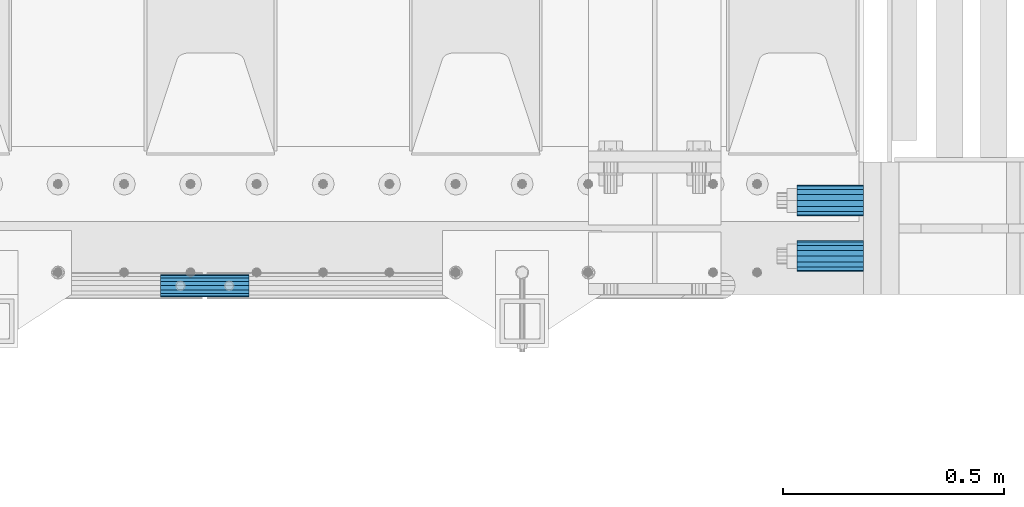
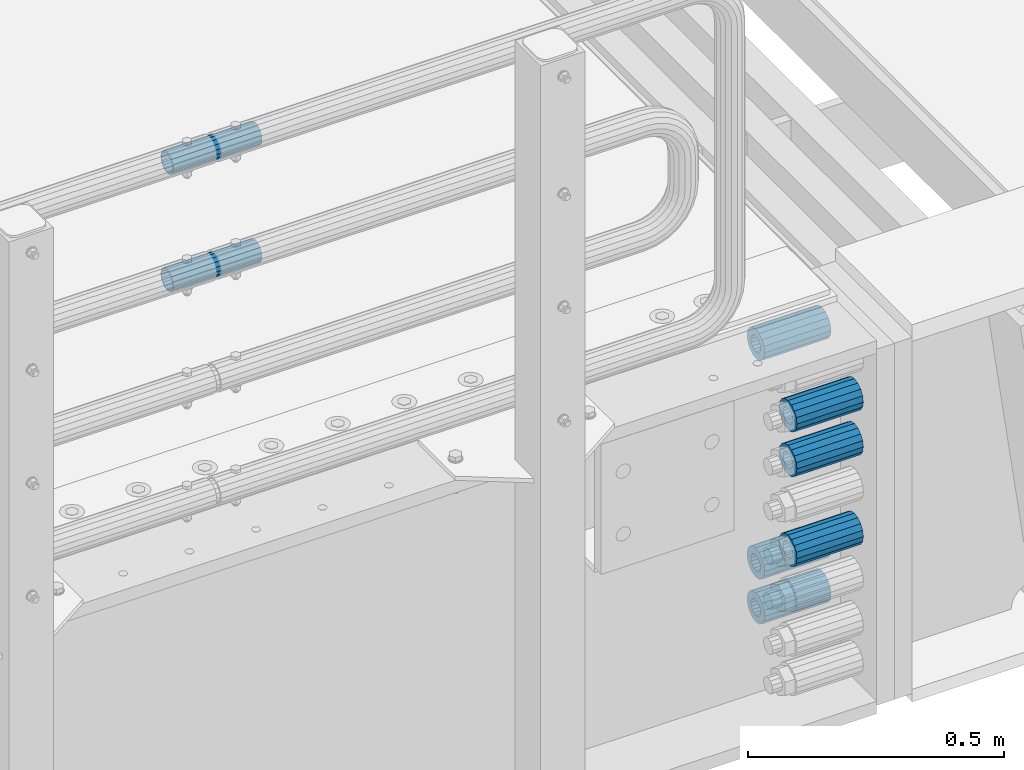
# One storey, part 127 of 219: 8 beams.
"""IFC2X3 building model written with IfcOpenShell, lengths in millimetres."""

from ifc_helpers import new_model, si_unit, frame, origin_with_axes, place, context, subcontext, project, spatial, faceted_brep, material, type_object, element, save


model = new_model("IFC2X3")

# Units and contexts
model_context = context("Model", 3, precision=1e-05, world=origin_with_axes())
body_context = subcontext(model_context, "Body", "Model", "MODEL_VIEW")
ifc_project = project(units=[si_unit("LENGTHUNIT", "METRE", prefix="MILLI"), si_unit("AREAUNIT", "SQUARE_METRE"), si_unit("VOLUMEUNIT", "CUBIC_METRE"), si_unit("MASSUNIT", "GRAM", prefix="KILO"), si_unit("TIMEUNIT", "SECOND"), si_unit("PLANEANGLEUNIT", "RADIAN"), si_unit("SOLIDANGLEUNIT", "STERADIAN"), si_unit("THERMODYNAMICTEMPERATUREUNIT", "DEGREE_CELSIUS"), si_unit("LUMINOUSINTENSITYUNIT", "LUMEN")], contexts=[model_context])

# Site, building, storey
site_placement = place(None, origin_with_axes())
site = spatial("IfcSite", under=ifc_project, at=site_placement, CompositionType="ELEMENT")
building_placement = place(site_placement, origin_with_axes())
building = spatial("IfcBuilding", under=site, at=building_placement, Name="Standard", CompositionType="ELEMENT")
storey_placement = place(building_placement, origin_with_axes())
storey = spatial("IfcBuildingStorey", under=building, at=storey_placement, Name="Undefined", CompositionType="ELEMENT", Elevation=0.0)

# Beams
ifc_material = material()
beam_type_1 = type_object("IfcBeamType", PredefinedType="NOTDEFINED")
beam_1_placement = place(storey_placement, frame((13877.0, 23937.0, -285.0), z_axis=(0.0, 0.0, 1.0), x_axis=(1.0, 0.0, 0.0)))
element("IfcBeam", 1, at=beam_1_placement, inside=storey, type_object=beam_type_1, material=ifc_material, context=body_context, shape_type="Brep", body=[
    faceted_brep([(-1.31236447487026e-07, -18.99999999955, -6.26823748461902e-09), (0.0, -17.5537111177146, 7.27098521493673), (150.0, -17.5537111177146, 7.27098521493673), (150.0, -19.0, 0.0), (0.0, -13.4350288425449, 13.4350288425444), (150.0, -13.4350288425449, 13.4350288425444), (0.0, -7.27098521493826, 17.5537111177144), (150.0, -7.27098521493826, 17.5537111177144), (-6.32644514553249e-09, 4.50427251053043e-10, 18.9999999937318), (150.0, 0.0, 19.0), (0.0, 7.27098521493826, 17.5537111177144), (150.0, 7.27098521493826, 17.5537111177144), (0.0, 13.4350288425449, 13.4350288425444), (150.0, 13.4350288425449, 13.4350288425444), (0.0, 17.5537111177146, 7.27098521493673), (150.0, 17.5537111177146, 7.27098521493673), (1.33248249767348e-07, 19.00000000045, -6.26823748461902e-09), (150.0, 19.0, 0.0), (0.0, 17.5537111177146, -7.27098521493673), (150.0, 17.5537111177146, -7.27098521493673), (0.0, 13.4350288425449, -13.4350288425444), (150.0, 13.4350288425449, -13.4350288425444), (0.0, 7.27098521493826, -17.5537111177144), (150.0, 7.27098521493826, -17.5537111177144), (8.33824742585421e-09, 4.50199877377599e-10, -19.0000000062664), (150.0, 0.0, -19.0), (0.0, -7.27098521493826, -17.5537111177144), (150.0, -7.27098521493826, -17.5537111177144), (0.0, -13.4350288425449, -13.4350288425444), (150.0, -13.4350288425449, -13.4350288425444), (0.0, -17.5537111177146, -7.27098521493673), (150.0, -17.5537111177146, -7.27098521493673), (1.81898940354586e-12, -35.0, 0.0), (3.63797880709171e-12, -32.335783637895, -13.3939201327776), (150.0, -32.3357836378964, -13.3939201327782), (150.0, -35.0, 0.0), (5.45696821063757e-12, -24.7487373415292, -24.7487373415279), (150.0, -24.7487373415279, -24.7487373415292), (7.27595761418343e-12, -13.3939201327781, -32.3357836378927), (150.0, -13.3939201327776, -32.335783637895), (9.09494701772928e-12, 0.0, -35.0000000000036), (150.0, 0.0, -35.0), (7.27595761418343e-12, 13.3939201327782, -32.3357836378927), (150.0, 13.3939201327776, -32.335783637895), (5.45696821063757e-12, 24.7487373415292, -24.7487373415279), (150.0, 24.7487373415279, -24.7487373415291), (3.63797880709171e-12, 32.335783637895, -13.3939201327776), (150.0, 32.3357836378964, -13.3939201327781), (1.81898940354586e-12, 35.0, 0.0), (150.0, 35.0, 0.0), (0.0, 32.335783637895, 13.3939201327776), (150.0, 32.3357836378964, 13.3939201327781), (-1.81898940354586e-12, 24.7487373415292, 24.7487373415242), (150.0, 24.7487373415279, 24.7487373415292), (-3.63797880709171e-12, 13.3939201327781, 32.3357836378927), (150.0, 13.3939201327776, 32.335783637895), (-5.45696821063757e-12, 0.0, 35.0), (150.0, 0.0, 35.0), (-3.63797880709171e-12, -13.3939201327781, 32.3357836378927), (150.0, -13.3939201327776, 32.335783637895), (-1.81898940354586e-12, -24.7487373415292, 24.7487373415242), (150.0, -24.7487373415279, 24.7487373415292), (0.0, -32.335783637895, 13.3939201327776), (150.0, -32.3357836378964, 13.3939201327781)], [[[0, 1, 2, 3]], [[1, 4, 5, 2]], [[4, 6, 7, 5]], [[6, 8, 9, 7]], [[8, 10, 11, 9]], [[10, 12, 13, 11]], [[12, 14, 15, 13]], [[14, 16, 17, 15]], [[16, 18, 19, 17]], [[18, 20, 21, 19]], [[20, 22, 23, 21]], [[22, 24, 25, 23]], [[24, 26, 27, 25]], [[26, 28, 29, 27]], [[28, 30, 31, 29]], [[30, 0, 3, 31]], [[32, 33, 34, 35]], [[33, 36, 37, 34]], [[36, 38, 39, 37]], [[38, 40, 41, 39]], [[40, 42, 43, 41]], [[42, 44, 45, 43]], [[44, 46, 47, 45]], [[46, 48, 49, 47]], [[48, 50, 51, 49]], [[50, 52, 53, 51]], [[52, 54, 55, 53]], [[54, 56, 57, 55]], [[56, 58, 59, 57]], [[58, 60, 61, 59]], [[60, 62, 63, 61]], [[62, 32, 35, 63]], [[37, 39, 41, 43, 45, 47, 49, 51, 53, 55, 57, 59, 61, 63, 35, 34], [5, 7, 9, 11, 13, 15, 17, 19, 21, 23, 25, 27, 29, 31, 3, 2]], [[62, 60, 58, 56, 54, 52, 50, 48, 46, 44, 42, 40, 38, 36, 33, 32], [30, 28, 26, 24, 22, 20, 18, 16, 14, 12, 10, 8, 6, 4, 1, 0]]]),
])
beam_2_placement = place(storey_placement, frame((13877.0, 24063.0, -606.0), z_axis=(0.0, 0.0, 1.0), x_axis=(1.0, 0.0, 0.0)))
element("IfcBeam", 2, at=beam_2_placement, inside=storey, type_object=beam_type_1, material=ifc_material, context=body_context, shape_type="Brep", body=[
    faceted_brep([(-1.31236447487026e-07, -18.99999999955, -6.26823748461902e-09), (0.0, -17.5537111177146, 7.27098521493673), (150.0, -17.5537111177146, 7.27098521493673), (150.0, -19.0, 0.0), (0.0, -13.4350288425449, 13.4350288425444), (150.0, -13.4350288425449, 13.4350288425444), (0.0, -7.27098521493826, 17.5537111177144), (150.0, -7.27098521493826, 17.5537111177144), (-6.32644514553249e-09, 4.50427251053043e-10, 18.9999999937318), (150.0, 0.0, 19.0), (0.0, 7.27098521493826, 17.5537111177144), (150.0, 7.27098521493826, 17.5537111177144), (0.0, 13.4350288425449, 13.4350288425444), (150.0, 13.4350288425449, 13.4350288425444), (0.0, 17.5537111177146, 7.27098521493673), (150.0, 17.5537111177146, 7.27098521493673), (1.33248249767348e-07, 19.00000000045, -6.26823748461902e-09), (150.0, 19.0, 0.0), (0.0, 17.5537111177146, -7.27098521493673), (150.0, 17.5537111177146, -7.27098521493673), (0.0, 13.4350288425449, -13.4350288425444), (150.0, 13.4350288425449, -13.4350288425444), (0.0, 7.27098521493826, -17.5537111177144), (150.0, 7.27098521493826, -17.5537111177144), (8.33824742585421e-09, 4.50199877377599e-10, -19.0000000062664), (150.0, 0.0, -19.0), (0.0, -7.27098521493826, -17.5537111177144), (150.0, -7.27098521493826, -17.5537111177144), (0.0, -13.4350288425449, -13.4350288425444), (150.0, -13.4350288425449, -13.4350288425444), (0.0, -17.5537111177146, -7.27098521493673), (150.0, -17.5537111177146, -7.27098521493673), (1.81898940354586e-12, -35.0, 0.0), (3.63797880709171e-12, -32.335783637895, -13.3939201327776), (150.0, -32.3357836378964, -13.3939201327782), (150.0, -35.0, 0.0), (5.45696821063757e-12, -24.7487373415292, -24.7487373415279), (150.0, -24.7487373415279, -24.7487373415292), (7.27595761418343e-12, -13.3939201327781, -32.3357836378927), (150.0, -13.3939201327776, -32.335783637895), (9.09494701772928e-12, 0.0, -35.0000000000036), (150.0, 0.0, -35.0), (7.27595761418343e-12, 13.3939201327782, -32.3357836378927), (150.0, 13.3939201327776, -32.335783637895), (5.45696821063757e-12, 24.7487373415292, -24.7487373415279), (150.0, 24.7487373415279, -24.7487373415291), (3.63797880709171e-12, 32.335783637895, -13.3939201327776), (150.0, 32.3357836378964, -13.3939201327781), (1.81898940354586e-12, 35.0, 0.0), (150.0, 35.0, 0.0), (0.0, 32.335783637895, 13.3939201327776), (150.0, 32.3357836378964, 13.3939201327781), (-1.81898940354586e-12, 24.7487373415292, 24.7487373415242), (150.0, 24.7487373415279, 24.7487373415292), (-3.63797880709171e-12, 13.3939201327781, 32.3357836378927), (150.0, 13.3939201327776, 32.335783637895), (-5.45696821063757e-12, 0.0, 35.0), (150.0, 0.0, 35.0), (-3.63797880709171e-12, -13.3939201327781, 32.3357836378927), (150.0, -13.3939201327776, 32.335783637895), (-1.81898940354586e-12, -24.7487373415292, 24.7487373415242), (150.0, -24.7487373415279, 24.7487373415292), (0.0, -32.335783637895, 13.3939201327776), (150.0, -32.3357836378964, 13.3939201327781)], [[[0, 1, 2, 3]], [[1, 4, 5, 2]], [[4, 6, 7, 5]], [[6, 8, 9, 7]], [[8, 10, 11, 9]], [[10, 12, 13, 11]], [[12, 14, 15, 13]], [[14, 16, 17, 15]], [[16, 18, 19, 17]], [[18, 20, 21, 19]], [[20, 22, 23, 21]], [[22, 24, 25, 23]], [[24, 26, 27, 25]], [[26, 28, 29, 27]], [[28, 30, 31, 29]], [[30, 0, 3, 31]], [[32, 33, 34, 35]], [[33, 36, 37, 34]], [[36, 38, 39, 37]], [[38, 40, 41, 39]], [[40, 42, 43, 41]], [[42, 44, 45, 43]], [[44, 46, 47, 45]], [[46, 48, 49, 47]], [[48, 50, 51, 49]], [[50, 52, 53, 51]], [[52, 54, 55, 53]], [[54, 56, 57, 55]], [[56, 58, 59, 57]], [[58, 60, 61, 59]], [[60, 62, 63, 61]], [[62, 32, 35, 63]], [[37, 39, 41, 43, 45, 47, 49, 51, 53, 55, 57, 59, 61, 63, 35, 34], [5, 7, 9, 11, 13, 15, 17, 19, 21, 23, 25, 27, 29, 31, 3, 2]], [[62, 60, 58, 56, 54, 52, 50, 48, 46, 44, 42, 40, 38, 36, 33, 32], [30, 28, 26, 24, 22, 20, 18, 16, 14, 12, 10, 8, 6, 4, 1, 0]]]),
])
beam_3_placement = place(storey_placement, frame((13877.0, 24063.0, -713.0), z_axis=(0.0, 0.0, 1.0), x_axis=(1.0, 0.0, 0.0)))
element("IfcBeam", 3, at=beam_3_placement, inside=storey, type_object=beam_type_1, material=ifc_material, context=body_context, shape_type="Brep", body=[
    faceted_brep([(-1.31236447487026e-07, -18.99999999955, -6.26823748461902e-09), (0.0, -17.5537111177146, 7.27098521493673), (150.0, -17.5537111177146, 7.27098521493673), (150.0, -19.0, 0.0), (0.0, -13.4350288425449, 13.4350288425444), (150.0, -13.4350288425449, 13.4350288425444), (0.0, -7.27098521493826, 17.5537111177144), (150.0, -7.27098521493826, 17.5537111177144), (-6.32644514553249e-09, 4.50427251053043e-10, 18.9999999937318), (150.0, 0.0, 19.0), (0.0, 7.27098521493826, 17.5537111177144), (150.0, 7.27098521493826, 17.5537111177144), (0.0, 13.4350288425449, 13.4350288425444), (150.0, 13.4350288425449, 13.4350288425444), (0.0, 17.5537111177146, 7.27098521493673), (150.0, 17.5537111177146, 7.27098521493673), (1.33248249767348e-07, 19.00000000045, -6.26823748461902e-09), (150.0, 19.0, 0.0), (0.0, 17.5537111177146, -7.27098521493673), (150.0, 17.5537111177146, -7.27098521493673), (0.0, 13.4350288425449, -13.4350288425444), (150.0, 13.4350288425449, -13.4350288425444), (0.0, 7.27098521493826, -17.5537111177144), (150.0, 7.27098521493826, -17.5537111177144), (8.33824742585421e-09, 4.50199877377599e-10, -19.0000000062664), (150.0, 0.0, -19.0), (0.0, -7.27098521493826, -17.5537111177144), (150.0, -7.27098521493826, -17.5537111177144), (0.0, -13.4350288425449, -13.4350288425444), (150.0, -13.4350288425449, -13.4350288425444), (0.0, -17.5537111177146, -7.27098521493673), (150.0, -17.5537111177146, -7.27098521493673), (1.81898940354586e-12, -35.0, 0.0), (3.63797880709171e-12, -32.335783637895, -13.3939201327776), (150.0, -32.3357836378964, -13.3939201327782), (150.0, -35.0, 0.0), (5.45696821063757e-12, -24.7487373415292, -24.7487373415279), (150.0, -24.7487373415279, -24.7487373415292), (7.27595761418343e-12, -13.3939201327781, -32.3357836378927), (150.0, -13.3939201327776, -32.335783637895), (9.09494701772928e-12, 0.0, -35.0000000000036), (150.0, 0.0, -35.0), (7.27595761418343e-12, 13.3939201327782, -32.3357836378927), (150.0, 13.3939201327776, -32.335783637895), (5.45696821063757e-12, 24.7487373415292, -24.7487373415279), (150.0, 24.7487373415279, -24.7487373415291), (3.63797880709171e-12, 32.335783637895, -13.3939201327776), (150.0, 32.3357836378964, -13.3939201327781), (1.81898940354586e-12, 35.0, 0.0), (150.0, 35.0, 0.0), (0.0, 32.335783637895, 13.3939201327776), (150.0, 32.3357836378964, 13.3939201327781), (-1.81898940354586e-12, 24.7487373415292, 24.7487373415242), (150.0, 24.7487373415279, 24.7487373415292), (-3.63797880709171e-12, 13.3939201327781, 32.3357836378927), (150.0, 13.3939201327776, 32.335783637895), (-5.45696821063757e-12, 0.0, 35.0), (150.0, 0.0, 35.0), (-3.63797880709171e-12, -13.3939201327781, 32.3357836378927), (150.0, -13.3939201327776, 32.335783637895), (-1.81898940354586e-12, -24.7487373415292, 24.7487373415242), (150.0, -24.7487373415279, 24.7487373415292), (0.0, -32.335783637895, 13.3939201327776), (150.0, -32.3357836378964, 13.3939201327781)], [[[0, 1, 2, 3]], [[1, 4, 5, 2]], [[4, 6, 7, 5]], [[6, 8, 9, 7]], [[8, 10, 11, 9]], [[10, 12, 13, 11]], [[12, 14, 15, 13]], [[14, 16, 17, 15]], [[16, 18, 19, 17]], [[18, 20, 21, 19]], [[20, 22, 23, 21]], [[22, 24, 25, 23]], [[24, 26, 27, 25]], [[26, 28, 29, 27]], [[28, 30, 31, 29]], [[30, 0, 3, 31]], [[32, 33, 34, 35]], [[33, 36, 37, 34]], [[36, 38, 39, 37]], [[38, 40, 41, 39]], [[40, 42, 43, 41]], [[42, 44, 45, 43]], [[44, 46, 47, 45]], [[46, 48, 49, 47]], [[48, 50, 51, 49]], [[50, 52, 53, 51]], [[52, 54, 55, 53]], [[54, 56, 57, 55]], [[56, 58, 59, 57]], [[58, 60, 61, 59]], [[60, 62, 63, 61]], [[62, 32, 35, 63]], [[37, 39, 41, 43, 45, 47, 49, 51, 53, 55, 57, 59, 61, 63, 35, 34], [5, 7, 9, 11, 13, 15, 17, 19, 21, 23, 25, 27, 29, 31, 3, 2]], [[62, 60, 58, 56, 54, 52, 50, 48, 46, 44, 42, 40, 38, 36, 33, 32], [30, 28, 26, 24, 22, 20, 18, 16, 14, 12, 10, 8, 6, 4, 1, 0]]]),
])
beam_4_placement = place(storey_placement, frame((13877.0, 23937.0, -499.0), z_axis=(0.0, 0.0, 1.0), x_axis=(1.0, 0.0, 0.0)))
element("IfcBeam", 4, at=beam_4_placement, inside=storey, type_object=beam_type_1, material=ifc_material, context=body_context, shape_type="Brep", body=[
    faceted_brep([(-1.31236447487026e-07, -18.99999999955, -6.26823748461902e-09), (0.0, -17.5537111177146, 7.27098521493673), (150.0, -17.5537111177146, 7.27098521493673), (150.0, -19.0, 0.0), (0.0, -13.4350288425449, 13.4350288425444), (150.0, -13.4350288425449, 13.4350288425444), (0.0, -7.27098521493826, 17.5537111177144), (150.0, -7.27098521493826, 17.5537111177144), (-6.32644514553249e-09, 4.50427251053043e-10, 18.9999999937318), (150.0, 0.0, 19.0), (0.0, 7.27098521493826, 17.5537111177144), (150.0, 7.27098521493826, 17.5537111177144), (0.0, 13.4350288425449, 13.4350288425444), (150.0, 13.4350288425449, 13.4350288425444), (0.0, 17.5537111177146, 7.27098521493673), (150.0, 17.5537111177146, 7.27098521493673), (1.33248249767348e-07, 19.00000000045, -6.26823748461902e-09), (150.0, 19.0, 0.0), (0.0, 17.5537111177146, -7.27098521493673), (150.0, 17.5537111177146, -7.27098521493673), (0.0, 13.4350288425449, -13.4350288425444), (150.0, 13.4350288425449, -13.4350288425444), (0.0, 7.27098521493826, -17.5537111177144), (150.0, 7.27098521493826, -17.5537111177144), (8.33824742585421e-09, 4.50199877377599e-10, -19.0000000062664), (150.0, 0.0, -19.0), (0.0, -7.27098521493826, -17.5537111177144), (150.0, -7.27098521493826, -17.5537111177144), (0.0, -13.4350288425449, -13.4350288425444), (150.0, -13.4350288425449, -13.4350288425444), (0.0, -17.5537111177146, -7.27098521493673), (150.0, -17.5537111177146, -7.27098521493673), (1.81898940354586e-12, -35.0, 0.0), (3.63797880709171e-12, -32.335783637895, -13.3939201327776), (150.0, -32.3357836378964, -13.3939201327782), (150.0, -35.0, 0.0), (5.45696821063757e-12, -24.7487373415292, -24.7487373415279), (150.0, -24.7487373415279, -24.7487373415292), (7.27595761418343e-12, -13.3939201327781, -32.3357836378927), (150.0, -13.3939201327776, -32.335783637895), (9.09494701772928e-12, 0.0, -35.0000000000036), (150.0, 0.0, -35.0), (7.27595761418343e-12, 13.3939201327782, -32.3357836378927), (150.0, 13.3939201327776, -32.335783637895), (5.45696821063757e-12, 24.7487373415292, -24.7487373415279), (150.0, 24.7487373415279, -24.7487373415291), (3.63797880709171e-12, 32.335783637895, -13.3939201327776), (150.0, 32.3357836378964, -13.3939201327781), (1.81898940354586e-12, 35.0, 0.0), (150.0, 35.0, 0.0), (0.0, 32.335783637895, 13.3939201327776), (150.0, 32.3357836378964, 13.3939201327781), (-1.81898940354586e-12, 24.7487373415292, 24.7487373415242), (150.0, 24.7487373415279, 24.7487373415292), (-3.63797880709171e-12, 13.3939201327781, 32.3357836378927), (150.0, 13.3939201327776, 32.335783637895), (-5.45696821063757e-12, 0.0, 35.0), (150.0, 0.0, 35.0), (-3.63797880709171e-12, -13.3939201327781, 32.3357836378927), (150.0, -13.3939201327776, 32.335783637895), (-1.81898940354586e-12, -24.7487373415292, 24.7487373415242), (150.0, -24.7487373415279, 24.7487373415292), (0.0, -32.335783637895, 13.3939201327776), (150.0, -32.3357836378964, 13.3939201327781)], [[[0, 1, 2, 3]], [[1, 4, 5, 2]], [[4, 6, 7, 5]], [[6, 8, 9, 7]], [[8, 10, 11, 9]], [[10, 12, 13, 11]], [[12, 14, 15, 13]], [[14, 16, 17, 15]], [[16, 18, 19, 17]], [[18, 20, 21, 19]], [[20, 22, 23, 21]], [[22, 24, 25, 23]], [[24, 26, 27, 25]], [[26, 28, 29, 27]], [[28, 30, 31, 29]], [[30, 0, 3, 31]], [[32, 33, 34, 35]], [[33, 36, 37, 34]], [[36, 38, 39, 37]], [[38, 40, 41, 39]], [[40, 42, 43, 41]], [[42, 44, 45, 43]], [[44, 46, 47, 45]], [[46, 48, 49, 47]], [[48, 50, 51, 49]], [[50, 52, 53, 51]], [[52, 54, 55, 53]], [[54, 56, 57, 55]], [[56, 58, 59, 57]], [[58, 60, 61, 59]], [[60, 62, 63, 61]], [[62, 32, 35, 63]], [[37, 39, 41, 43, 45, 47, 49, 51, 53, 55, 57, 59, 61, 63, 35, 34], [5, 7, 9, 11, 13, 15, 17, 19, 21, 23, 25, 27, 29, 31, 3, 2]], [[62, 60, 58, 56, 54, 52, 50, 48, 46, 44, 42, 40, 38, 36, 33, 32], [30, 28, 26, 24, 22, 20, 18, 16, 14, 12, 10, 8, 6, 4, 1, 0]]]),
])
beam_5_placement = place(storey_placement, frame((13877.0, 24063.0, -84.0000000000001), z_axis=(0.0, 0.0, 1.0), x_axis=(1.0, 0.0, 0.0)))
element("IfcBeam", 5, at=beam_5_placement, inside=storey, type_object=beam_type_1, material=ifc_material, context=body_context, shape_type="Brep", body=[
    faceted_brep([(-1.31236447487026e-07, -18.99999999955, -6.26823748461902e-09), (0.0, -17.5537111177146, 7.27098521493673), (150.0, -17.5537111177146, 7.27098521493673), (150.0, -19.0, 0.0), (0.0, -13.4350288425449, 13.4350288425444), (150.0, -13.4350288425449, 13.4350288425444), (0.0, -7.27098521493826, 17.5537111177144), (150.0, -7.27098521493826, 17.5537111177144), (-6.32644514553249e-09, 4.50427251053043e-10, 18.9999999937318), (150.0, 0.0, 19.0), (0.0, 7.27098521493826, 17.5537111177144), (150.0, 7.27098521493826, 17.5537111177144), (0.0, 13.4350288425449, 13.4350288425444), (150.0, 13.4350288425449, 13.4350288425444), (0.0, 17.5537111177146, 7.27098521493673), (150.0, 17.5537111177146, 7.27098521493673), (1.33248249767348e-07, 19.00000000045, -6.26823748461902e-09), (150.0, 19.0, 0.0), (0.0, 17.5537111177146, -7.27098521493673), (150.0, 17.5537111177146, -7.27098521493673), (0.0, 13.4350288425449, -13.4350288425444), (150.0, 13.4350288425449, -13.4350288425444), (0.0, 7.27098521493826, -17.5537111177144), (150.0, 7.27098521493826, -17.5537111177144), (8.33824742585421e-09, 4.50199877377599e-10, -19.0000000062664), (150.0, 0.0, -19.0), (0.0, -7.27098521493826, -17.5537111177144), (150.0, -7.27098521493826, -17.5537111177144), (0.0, -13.4350288425449, -13.4350288425444), (150.0, -13.4350288425449, -13.4350288425444), (0.0, -17.5537111177146, -7.27098521493673), (150.0, -17.5537111177146, -7.27098521493673), (1.81898940354586e-12, -35.0, 0.0), (3.63797880709171e-12, -32.335783637895, -13.3939201327776), (150.0, -32.3357836378964, -13.3939201327782), (150.0, -35.0, 0.0), (5.45696821063757e-12, -24.7487373415292, -24.7487373415279), (150.0, -24.7487373415279, -24.7487373415292), (7.27595761418343e-12, -13.3939201327781, -32.3357836378927), (150.0, -13.3939201327776, -32.335783637895), (9.09494701772928e-12, 0.0, -35.0000000000036), (150.0, 0.0, -35.0), (7.27595761418343e-12, 13.3939201327782, -32.3357836378927), (150.0, 13.3939201327776, -32.335783637895), (5.45696821063757e-12, 24.7487373415292, -24.7487373415279), (150.0, 24.7487373415279, -24.7487373415291), (3.63797880709171e-12, 32.335783637895, -13.3939201327776), (150.0, 32.3357836378964, -13.3939201327781), (1.81898940354586e-12, 35.0, 0.0), (150.0, 35.0, 0.0), (0.0, 32.335783637895, 13.3939201327776), (150.0, 32.3357836378964, 13.3939201327781), (-1.81898940354586e-12, 24.7487373415292, 24.7487373415242), (150.0, 24.7487373415279, 24.7487373415292), (-3.63797880709171e-12, 13.3939201327781, 32.3357836378927), (150.0, 13.3939201327776, 32.335783637895), (-5.45696821063757e-12, 0.0, 35.0), (150.0, 0.0, 35.0), (-3.63797880709171e-12, -13.3939201327781, 32.3357836378927), (150.0, -13.3939201327776, 32.335783637895), (-1.81898940354586e-12, -24.7487373415292, 24.7487373415242), (150.0, -24.7487373415279, 24.7487373415292), (0.0, -32.335783637895, 13.3939201327776), (150.0, -32.3357836378964, 13.3939201327781)], [[[0, 1, 2, 3]], [[1, 4, 5, 2]], [[4, 6, 7, 5]], [[6, 8, 9, 7]], [[8, 10, 11, 9]], [[10, 12, 13, 11]], [[12, 14, 15, 13]], [[14, 16, 17, 15]], [[16, 18, 19, 17]], [[18, 20, 21, 19]], [[20, 22, 23, 21]], [[22, 24, 25, 23]], [[24, 26, 27, 25]], [[26, 28, 29, 27]], [[28, 30, 31, 29]], [[30, 0, 3, 31]], [[32, 33, 34, 35]], [[33, 36, 37, 34]], [[36, 38, 39, 37]], [[38, 40, 41, 39]], [[40, 42, 43, 41]], [[42, 44, 45, 43]], [[44, 46, 47, 45]], [[46, 48, 49, 47]], [[48, 50, 51, 49]], [[50, 52, 53, 51]], [[52, 54, 55, 53]], [[54, 56, 57, 55]], [[56, 58, 59, 57]], [[58, 60, 61, 59]], [[60, 62, 63, 61]], [[62, 32, 35, 63]], [[37, 39, 41, 43, 45, 47, 49, 51, 53, 55, 57, 59, 61, 63, 35, 34], [5, 7, 9, 11, 13, 15, 17, 19, 21, 23, 25, 27, 29, 31, 3, 2]], [[62, 60, 58, 56, 54, 52, 50, 48, 46, 44, 42, 40, 38, 36, 33, 32], [30, 28, 26, 24, 22, 20, 18, 16, 14, 12, 10, 8, 6, 4, 1, 0]]]),
])
beam_6_placement = place(storey_placement, frame((13877.0, 23937.0, -178.0), z_axis=(0.0, 0.0, 1.0), x_axis=(1.0, 0.0, 0.0)))
element("IfcBeam", 6, at=beam_6_placement, inside=storey, type_object=beam_type_1, material=ifc_material, context=body_context, shape_type="Brep", body=[
    faceted_brep([(-1.31236447487026e-07, -18.99999999955, -6.26823748461902e-09), (0.0, -17.5537111177146, 7.27098521493673), (150.0, -17.5537111177146, 7.27098521493673), (150.0, -19.0, 0.0), (0.0, -13.4350288425449, 13.4350288425444), (150.0, -13.4350288425449, 13.4350288425444), (0.0, -7.27098521493826, 17.5537111177144), (150.0, -7.27098521493826, 17.5537111177144), (-6.32644514553249e-09, 4.50427251053043e-10, 18.9999999937318), (150.0, 0.0, 19.0), (0.0, 7.27098521493826, 17.5537111177144), (150.0, 7.27098521493826, 17.5537111177144), (0.0, 13.4350288425449, 13.4350288425444), (150.0, 13.4350288425449, 13.4350288425444), (0.0, 17.5537111177146, 7.27098521493673), (150.0, 17.5537111177146, 7.27098521493673), (1.33248249767348e-07, 19.00000000045, -6.26823748461902e-09), (150.0, 19.0, 0.0), (0.0, 17.5537111177146, -7.27098521493673), (150.0, 17.5537111177146, -7.27098521493673), (0.0, 13.4350288425449, -13.4350288425444), (150.0, 13.4350288425449, -13.4350288425444), (0.0, 7.27098521493826, -17.5537111177144), (150.0, 7.27098521493826, -17.5537111177144), (8.33824742585421e-09, 4.50199877377599e-10, -19.0000000062664), (150.0, 0.0, -19.0), (0.0, -7.27098521493826, -17.5537111177144), (150.0, -7.27098521493826, -17.5537111177144), (0.0, -13.4350288425449, -13.4350288425444), (150.0, -13.4350288425449, -13.4350288425444), (0.0, -17.5537111177146, -7.27098521493673), (150.0, -17.5537111177146, -7.27098521493673), (1.81898940354586e-12, -35.0, 0.0), (3.63797880709171e-12, -32.335783637895, -13.3939201327776), (150.0, -32.3357836378964, -13.3939201327782), (150.0, -35.0, 0.0), (5.45696821063757e-12, -24.7487373415292, -24.7487373415279), (150.0, -24.7487373415279, -24.7487373415292), (7.27595761418343e-12, -13.3939201327781, -32.3357836378927), (150.0, -13.3939201327776, -32.335783637895), (9.09494701772928e-12, 0.0, -35.0000000000036), (150.0, 0.0, -35.0), (7.27595761418343e-12, 13.3939201327782, -32.3357836378927), (150.0, 13.3939201327776, -32.335783637895), (5.45696821063757e-12, 24.7487373415292, -24.7487373415279), (150.0, 24.7487373415279, -24.7487373415291), (3.63797880709171e-12, 32.335783637895, -13.3939201327776), (150.0, 32.3357836378964, -13.3939201327781), (1.81898940354586e-12, 35.0, 0.0), (150.0, 35.0, 0.0), (0.0, 32.335783637895, 13.3939201327776), (150.0, 32.3357836378964, 13.3939201327781), (-1.81898940354586e-12, 24.7487373415292, 24.7487373415242), (150.0, 24.7487373415279, 24.7487373415292), (-3.63797880709171e-12, 13.3939201327781, 32.3357836378927), (150.0, 13.3939201327776, 32.335783637895), (-5.45696821063757e-12, 0.0, 35.0), (150.0, 0.0, 35.0), (-3.63797880709171e-12, -13.3939201327781, 32.3357836378927), (150.0, -13.3939201327776, 32.335783637895), (-1.81898940354586e-12, -24.7487373415292, 24.7487373415242), (150.0, -24.7487373415279, 24.7487373415292), (0.0, -32.335783637895, 13.3939201327776), (150.0, -32.3357836378964, 13.3939201327781)], [[[0, 1, 2, 3]], [[1, 4, 5, 2]], [[4, 6, 7, 5]], [[6, 8, 9, 7]], [[8, 10, 11, 9]], [[10, 12, 13, 11]], [[12, 14, 15, 13]], [[14, 16, 17, 15]], [[16, 18, 19, 17]], [[18, 20, 21, 19]], [[20, 22, 23, 21]], [[22, 24, 25, 23]], [[24, 26, 27, 25]], [[26, 28, 29, 27]], [[28, 30, 31, 29]], [[30, 0, 3, 31]], [[32, 33, 34, 35]], [[33, 36, 37, 34]], [[36, 38, 39, 37]], [[38, 40, 41, 39]], [[40, 42, 43, 41]], [[42, 44, 45, 43]], [[44, 46, 47, 45]], [[46, 48, 49, 47]], [[48, 50, 51, 49]], [[50, 52, 53, 51]], [[52, 54, 55, 53]], [[54, 56, 57, 55]], [[56, 58, 59, 57]], [[58, 60, 61, 59]], [[60, 62, 63, 61]], [[62, 32, 35, 63]], [[37, 39, 41, 43, 45, 47, 49, 51, 53, 55, 57, 59, 61, 63, 35, 34], [5, 7, 9, 11, 13, 15, 17, 19, 21, 23, 25, 27, 29, 31, 3, 2]], [[62, 60, 58, 56, 54, 52, 50, 48, 46, 44, 42, 40, 38, 36, 33, 32], [30, 28, 26, 24, 22, 20, 18, 16, 14, 12, 10, 8, 6, 4, 1, 0]]]),
])
beam_type_2 = type_object("IfcBeamType", PredefinedType="NOTDEFINED")
beam_7_placement = place(storey_placement, frame((12436.9975029999, 23870.1500000004, 689.849999999747), z_axis=(0.0, 0.0, 1.0), x_axis=(1.0, 0.0, 0.0)))
element("IfcBeam", 7, at=beam_7_placement, inside=storey, type_object=beam_type_2, material=ifc_material, context=body_context, shape_type="Brep", body=[
    faceted_brep([(0.0, -21.9000000000015, 0.0), (0.0, -20.232961761998, 8.38076716879547), (200.0, -20.232961761998, 8.38076716879547), (200.0, -21.9000000000015, 0.0), (0.0, -15.4856385079838, 15.4856385079854), (200.0, -15.4856385079838, 15.4856385079854), (0.0, -8.38076716879732, 20.2329617619972), (200.0, -8.38076716879732, 20.2329617619972), (0.0, 0.0, 21.9), (200.0, 0.0, 21.9), (0.0, 8.38076716879732, 20.2329617619972), (200.0, 8.38076716879732, 20.2329617619972), (0.0, 15.4856385079838, 15.4856385079854), (200.0, 15.4856385079838, 15.4856385079854), (0.0, 20.232961761998, 8.38076716879547), (200.0, 20.232961761998, 8.38076716879547), (0.0, 21.9000000000015, 0.0), (200.0, 21.9000000000015, 0.0), (0.0, 20.232961761998, -8.38076716879547), (200.0, 20.232961761998, -8.38076716879547), (0.0, 15.4856385079838, -15.4856385079854), (200.0, 15.4856385079838, -15.4856385079854), (0.0, 8.38076716879732, -20.2329617619972), (200.0, 8.38076716879732, -20.2329617619972), (0.0, 0.0, -21.9), (200.0, 0.0, -21.9), (0.0, -8.38076716879732, -20.2329617619972), (200.0, -8.38076716879732, -20.2329617619972), (0.0, -15.4856385079838, -15.4856385079854), (200.0, -15.4856385079838, -15.4856385079854), (0.0, -20.232961761998, -8.38076716879547), (200.0, -20.232961761998, -8.38076716879547), (0.0, -25.5, 0.0), (0.0, -23.5589280790373, -9.7584275253098), (200.0, -23.5589280790373, -9.7584275253098), (200.0, -25.5, 0.0), (0.0, -18.0312229202536, -18.031222920257), (200.0, -18.0312229202536, -18.031222920257), (0.0, -9.75842752531025, -23.5589280790378), (200.0, -9.75842752531025, -23.5589280790378), (0.0, 0.0, -25.5), (200.0, 0.0, -25.5), (0.0, 9.75842752531025, -23.5589280790378), (200.0, 9.75842752531025, -23.5589280790378), (0.0, 18.0312229202536, -18.031222920257), (200.0, 18.0312229202536, -18.031222920257), (0.0, 23.5589280790373, -9.7584275253098), (200.0, 23.5589280790373, -9.7584275253098), (0.0, 25.5, 0.0), (200.0, 25.5, 0.0), (0.0, 23.5589280790373, 9.7584275253098), (200.0, 23.5589280790373, 9.7584275253098), (0.0, 18.0312229202536, 18.031222920257), (200.0, 18.0312229202536, 18.031222920257), (0.0, 9.75842752531025, 23.5589280790378), (200.0, 9.75842752531025, 23.5589280790378), (0.0, 0.0, 25.5), (200.0, 0.0, 25.5), (0.0, -9.75842752531025, 23.5589280790378), (200.0, -9.75842752531025, 23.5589280790378), (0.0, -18.0312229202536, 18.031222920257), (200.0, -18.0312229202536, 18.031222920257), (0.0, -23.5589280790373, 9.7584275253098), (200.0, -23.5589280790373, 9.7584275253098)], [[[0, 1, 2, 3]], [[1, 4, 5, 2]], [[4, 6, 7, 5]], [[6, 8, 9, 7]], [[8, 10, 11, 9]], [[10, 12, 13, 11]], [[12, 14, 15, 13]], [[14, 16, 17, 15]], [[16, 18, 19, 17]], [[18, 20, 21, 19]], [[20, 22, 23, 21]], [[22, 24, 25, 23]], [[24, 26, 27, 25]], [[26, 28, 29, 27]], [[28, 30, 31, 29]], [[30, 0, 3, 31]], [[32, 33, 34, 35]], [[33, 36, 37, 34]], [[36, 38, 39, 37]], [[38, 40, 41, 39]], [[40, 42, 43, 41]], [[42, 44, 45, 43]], [[44, 46, 47, 45]], [[46, 48, 49, 47]], [[48, 50, 51, 49]], [[50, 52, 53, 51]], [[52, 54, 55, 53]], [[54, 56, 57, 55]], [[56, 58, 59, 57]], [[58, 60, 61, 59]], [[60, 62, 63, 61]], [[62, 32, 35, 63]], [[37, 39, 41, 43, 45, 47, 49, 51, 53, 55, 57, 59, 61, 63, 35, 34], [5, 7, 9, 11, 13, 15, 17, 19, 21, 23, 25, 27, 29, 31, 3, 2]], [[62, 60, 58, 56, 54, 52, 50, 48, 46, 44, 42, 40, 38, 36, 33, 32], [30, 28, 26, 24, 22, 20, 18, 16, 14, 12, 10, 8, 6, 4, 1, 0]]]),
])
beam_8_placement = place(storey_placement, frame((12436.9975029999, 23870.1500000005, 969.849999999747), z_axis=(0.0, 0.0, 1.0), x_axis=(1.0, 0.0, 0.0)))
element("IfcBeam", 8, at=beam_8_placement, inside=storey, type_object=beam_type_2, material=ifc_material, context=body_context, shape_type="Brep", body=[
    faceted_brep([(0.0, -21.9000000000015, 0.0), (0.0, -20.232961761998, 8.38076716879547), (200.0, -20.232961761998, 8.38076716879547), (200.0, -21.9000000000015, 0.0), (0.0, -15.4856385079838, 15.4856385079854), (200.0, -15.4856385079838, 15.4856385079854), (0.0, -8.38076716879732, 20.2329617619972), (200.0, -8.38076716879732, 20.2329617619972), (0.0, 0.0, 21.9), (200.0, 0.0, 21.9), (0.0, 8.38076716879732, 20.2329617619972), (200.0, 8.38076716879732, 20.2329617619972), (0.0, 15.4856385079838, 15.4856385079854), (200.0, 15.4856385079838, 15.4856385079854), (0.0, 20.232961761998, 8.38076716879547), (200.0, 20.232961761998, 8.38076716879547), (0.0, 21.9000000000015, 0.0), (200.0, 21.9000000000015, 0.0), (0.0, 20.232961761998, -8.38076716879547), (200.0, 20.232961761998, -8.38076716879547), (0.0, 15.4856385079838, -15.4856385079854), (200.0, 15.4856385079838, -15.4856385079854), (0.0, 8.38076716879732, -20.2329617619972), (200.0, 8.38076716879732, -20.2329617619972), (0.0, 0.0, -21.9), (200.0, 0.0, -21.9), (0.0, -8.38076716879732, -20.2329617619972), (200.0, -8.38076716879732, -20.2329617619972), (0.0, -15.4856385079838, -15.4856385079854), (200.0, -15.4856385079838, -15.4856385079854), (0.0, -20.232961761998, -8.38076716879547), (200.0, -20.232961761998, -8.38076716879547), (0.0, -25.5, 0.0), (0.0, -23.5589280790373, -9.7584275253098), (200.0, -23.5589280790373, -9.7584275253098), (200.0, -25.5, 0.0), (0.0, -18.0312229202536, -18.031222920257), (200.0, -18.0312229202536, -18.031222920257), (0.0, -9.75842752531025, -23.5589280790378), (200.0, -9.75842752531025, -23.5589280790378), (0.0, 0.0, -25.5), (200.0, 0.0, -25.5), (0.0, 9.75842752531025, -23.5589280790378), (200.0, 9.75842752531025, -23.5589280790378), (0.0, 18.0312229202536, -18.031222920257), (200.0, 18.0312229202536, -18.031222920257), (0.0, 23.5589280790373, -9.7584275253098), (200.0, 23.5589280790373, -9.7584275253098), (0.0, 25.5, 0.0), (200.0, 25.5, 0.0), (0.0, 23.5589280790373, 9.7584275253098), (200.0, 23.5589280790373, 9.7584275253098), (0.0, 18.0312229202536, 18.031222920257), (200.0, 18.0312229202536, 18.031222920257), (0.0, 9.75842752531025, 23.5589280790378), (200.0, 9.75842752531025, 23.5589280790378), (0.0, 0.0, 25.5), (200.0, 0.0, 25.5), (0.0, -9.75842752531025, 23.5589280790378), (200.0, -9.75842752531025, 23.5589280790378), (0.0, -18.0312229202536, 18.031222920257), (200.0, -18.0312229202536, 18.031222920257), (0.0, -23.5589280790373, 9.7584275253098), (200.0, -23.5589280790373, 9.7584275253098)], [[[0, 1, 2, 3]], [[1, 4, 5, 2]], [[4, 6, 7, 5]], [[6, 8, 9, 7]], [[8, 10, 11, 9]], [[10, 12, 13, 11]], [[12, 14, 15, 13]], [[14, 16, 17, 15]], [[16, 18, 19, 17]], [[18, 20, 21, 19]], [[20, 22, 23, 21]], [[22, 24, 25, 23]], [[24, 26, 27, 25]], [[26, 28, 29, 27]], [[28, 30, 31, 29]], [[30, 0, 3, 31]], [[32, 33, 34, 35]], [[33, 36, 37, 34]], [[36, 38, 39, 37]], [[38, 40, 41, 39]], [[40, 42, 43, 41]], [[42, 44, 45, 43]], [[44, 46, 47, 45]], [[46, 48, 49, 47]], [[48, 50, 51, 49]], [[50, 52, 53, 51]], [[52, 54, 55, 53]], [[54, 56, 57, 55]], [[56, 58, 59, 57]], [[58, 60, 61, 59]], [[60, 62, 63, 61]], [[62, 32, 35, 63]], [[37, 39, 41, 43, 45, 47, 49, 51, 53, 55, 57, 59, 61, 63, 35, 34], [5, 7, 9, 11, 13, 15, 17, 19, 21, 23, 25, 27, 29, 31, 3, 2]], [[62, 60, 58, 56, 54, 52, 50, 48, 46, 44, 42, 40, 38, 36, 33, 32], [30, 28, 26, 24, 22, 20, 18, 16, 14, 12, 10, 8, 6, 4, 1, 0]]]),
])

save(model, "model.ifc")
